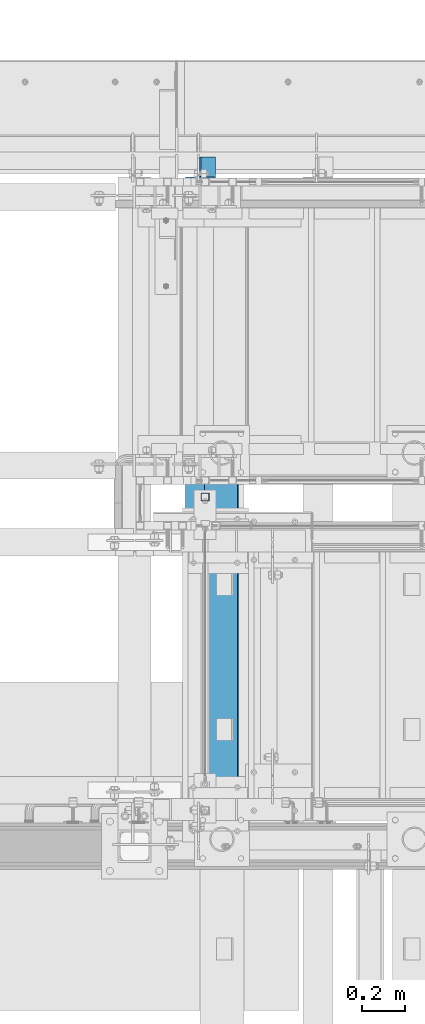
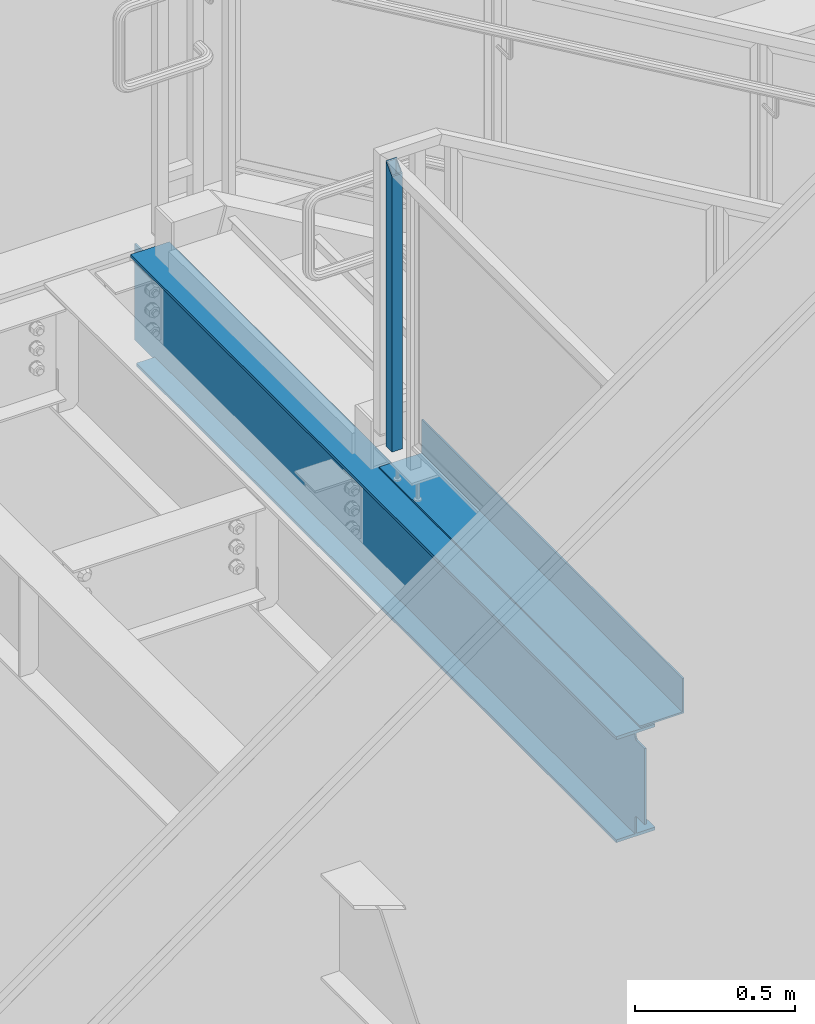
# One storey, part 780 of 1179: 2 beams, 1 member, 2 elements without a shape of their own.
"""IFC2X3 building model written with IfcOpenShell, lengths in millimetres."""

from ifc_helpers import new_model, si_unit, frame, origin_with_axes, place, context, subcontext, project, spatial, faceted_brep, material, type_object, element, aggregate, save


model = new_model("IFC2X3")

# Units and contexts
model_context = context("Model", 3, precision=1e-05, world=origin_with_axes())
body_context = subcontext(model_context, "Body", "Model", "MODEL_VIEW")
ifc_project = project(units=[si_unit("LENGTHUNIT", "METRE", prefix="MILLI"), si_unit("AREAUNIT", "SQUARE_METRE"), si_unit("VOLUMEUNIT", "CUBIC_METRE"), si_unit("MASSUNIT", "GRAM", prefix="KILO"), si_unit("TIMEUNIT", "SECOND"), si_unit("PLANEANGLEUNIT", "RADIAN"), si_unit("SOLIDANGLEUNIT", "STERADIAN"), si_unit("THERMODYNAMICTEMPERATUREUNIT", "DEGREE_CELSIUS"), si_unit("LUMINOUSINTENSITYUNIT", "LUMEN")], contexts=[model_context])

# Site, building, storey
site_placement = place(None, origin_with_axes())
site = spatial("IfcSite", under=ifc_project, at=site_placement, CompositionType="ELEMENT")
building_placement = place(site_placement, origin_with_axes())
building = spatial("IfcBuilding", under=site, at=building_placement, Name="Undefined", CompositionType="ELEMENT")
storey_placement = place(building_placement, origin_with_axes())
storey = spatial("IfcBuildingStorey", under=building, at=storey_placement, Name="Undefined", CompositionType="ELEMENT", Elevation=0.0)

# Assembly, member
assembly_1_placement = place(storey_placement, origin_with_axes())
assembly_1 = element("IfcElementAssembly", 1, at=assembly_1_placement, inside=storey, Name="GUARDRAIL", AssemblyPlace="NOTDEFINED", PredefinedType="RIGID_FRAME")
ifc_material_1 = material()
member_type = type_object("IfcMemberType", Name="HSS1-1/2X1-1/2X1/8", PredefinedType="NOTDEFINED")
member_placement = place(assembly_1_placement, frame((19605.6249999269, 39604.950001563, 8147.05), z_axis=(-1.0, 0.0, 0.0), x_axis=(0.0, 0.0, 1.0)))
member = element("IfcMember", 2, at=member_placement, type_object=member_type, material=ifc_material_1, Name="POST", ObjectType="HSS1-1/2X1-1/2X1/8", context=body_context, shape_type="Brep", body=[
    faceted_brep([(0.0, 15.8749992830017, -15.8749992829999), (0.0, -15.8749992830017, -15.8749992829999), (1050.92500131295, -15.874999282998, -15.8749992830017), (1082.67499987894, 15.874999282998, -15.8749992830017), (0.0, -15.8749992830017, 15.8749992829999), (1050.92500131295, -15.874999282998, 15.8749992830017), (0.0, 15.8749992830017, 15.8749992829999), (1082.67499987894, 15.874999282998, 15.8749992830017), (0.0, 19.0499992350015, -19.0499992349996), (0.0, 19.0499992350015, 19.0499992349996), (1085.84999983094, 19.0499992350015, 19.0499992350015), (1085.84999983094, 19.0499992350015, -19.0499992350015), (0.0, -19.0499992350015, 19.0499992349996), (1047.74999838855, -19.0499992350015, 19.0499992350015), (0.0, -19.0499992350015, -19.0499992349996), (1047.74999838855, -19.0499992350015, -19.0499992350015)], [[[0, 1, 2, 3]], [[1, 4, 5, 2]], [[4, 6, 7, 5]], [[6, 0, 3, 7]], [[8, 9, 10, 11]], [[9, 12, 13, 10]], [[12, 14, 15, 13]], [[14, 8, 11, 15]], [[13, 15, 11, 10], [5, 7, 3, 2]], [[14, 12, 9, 8], [6, 4, 1, 0]]]),
])
aggregate(assembly_1, [member])

# Assembly, beams
assembly_2_placement = place(storey_placement, origin_with_axes())
assembly_2 = element("IfcElementAssembly", 3, at=assembly_2_placement, inside=storey, Name="BEAM", AssemblyPlace="NOTDEFINED", PredefinedType="RIGID_FRAME")
ifc_material_2 = material(Name="STEEL/A36")
beam_type_1 = type_object("IfcBeamType", PredefinedType="NOTDEFINED")
beam_1_placement = place(assembly_2_placement, frame((19602.45, 38881.05, 8016.875), z_axis=(0.0, -1.0, 0.0), x_axis=(1.0, 0.0, 0.0)))
beam_1 = element("IfcBeam", 4, at=beam_1_placement, type_object=beam_type_1, material=ifc_material_2, Name="BENT PLATE", context=body_context, shape_type="Brep", body=[
    faceted_brep([(0.0, -3.17500000000018, -812.800000000003), (0.0, -3.17500000000018, 812.800000000003), (0.0, 3.17500000000018, 812.800000000003), (0.0, 3.17500000000018, -812.800000000003), (152.400000000005, 3.17500000000291, 812.800000000003), (152.400000000005, 3.17500000000291, -812.800000000003), (158.750000000004, -3.17499999999745, -812.800000000003), (158.750000000004, -3.17499999999745, 812.800000000003), (152.400000000005, 130.175000000003, 812.800000000003), (152.400000000005, 130.175000000003, -812.800000000003), (158.750000000004, 130.175000000003, 812.800000000003), (158.750000000004, 130.175000000003, -812.800000000003)], [[[0, 1, 2, 3]], [[3, 2, 4, 5]], [[1, 0, 6, 7]], [[5, 4, 8, 9]], [[4, 2, 1, 7, 10, 8]], [[7, 6, 11, 10]], [[6, 0, 3, 5, 9, 11]], [[10, 11, 9, 8]]]),
])
ifc_material_3 = material(Name="STEEL/A992")
beam_type_2 = type_object("IfcBeamType", Name="W16X31", PredefinedType="NOTDEFINED")
beam_2_placement = place(assembly_2_placement, frame((19583.4, 37985.7, 7812.0875), z_axis=(0.0, 0.0, 1.0), x_axis=(0.0, 1.0, 0.0)))
beam_2 = element("IfcBeam", 5, at=beam_2_placement, type_object=beam_type_2, material=ifc_material_3, Name="BEAM", ObjectType="W16X31", context=body_context, shape_type="Brep", body=[
    faceted_brep([(15.875, -3.17499999999927, -119.0625), (15.875, 3.17499999999927, -119.0625), (63.5000001907247, 3.17499999999927, -119.0625), (63.5000001907247, -3.17499999999927, -119.0625), (68.3600797087711, 3.17499999999927, -120.029229922588), (68.3600797087711, -3.17499999999927, -120.029229922588), (72.4802561769247, 3.17499999999927, -122.782243823066), (72.4802561769247, -3.17499999999927, -122.782243823066), (75.2332700773986, 3.17499999999927, -126.90242029122), (75.2332700773986, -3.17499999999927, -126.90242029122), (76.1999999999898, -3.17499999999927, -131.762499809265), (76.1999999999898, 3.17499999999927, -131.762499809265), (76.1999999999898, 3.17499999999927, -190.5), (76.1999999999898, 69.8499999999985, -190.5), (76.1999999999898, 69.8499999999985, -201.6125), (76.1999999999898, -69.8499999999985, -201.6125), (76.1999999999898, -69.8499999999985, -190.5), (76.1999999999898, -3.17499999999927, -190.5), (3102.76875, 69.8499999999985, 190.5), (3102.76875, 3.17499999999927, 190.5), (76.1999999999898, 3.17499999999927, 190.5), (76.1999999999898, 69.8499999999985, 190.5), (63.5000001907247, -3.17499999999927, 169.8625), (63.5000001907247, 3.17499999999927, 169.8625), (15.875, 3.17499999999927, 169.8625), (15.875, -3.17499999999927, 169.8625), (68.3600797087711, -3.17499999999927, 170.829229922588), (68.3600797087711, 3.17499999999927, 170.829229922588), (72.4802561769247, -3.17499999999927, 173.582243823066), (72.4802561769247, 3.17499999999927, 173.582243823066), (75.2332700773986, -3.17499999999927, 177.70242029122), (75.2332700773986, 3.17499999999927, 177.70242029122), (76.1999999999898, -3.17499999999927, 182.562499809265), (76.1999999999898, 3.17499999999927, 182.562499809265), (3102.76875, -69.8499999999985, 201.6125), (3102.76875, 69.8499999999985, 201.6125), (76.1999999999898, 69.8499999999985, 201.6125), (76.1999999999898, -69.8499999999985, 201.6125), (3102.76875, -69.8499999999985, 190.5), (76.1999999999898, -69.8499999999985, 190.5), (3102.76875, -3.17499999999927, 190.5), (76.1999999999898, -3.17499999999927, 190.5), (3102.76875, -3.17499999999927, 176.212499809266), (3102.76875, 3.17499999999927, 176.212499809266), (3102.76875, 3.17499999999927, 181.715), (3103.73547992259, -3.17499999999927, 171.35242029122), (3103.73547992259, 3.17499999999927, 171.35242029122), (3106.48849382307, -3.17499999999927, 167.232243823067), (3106.48849382307, 3.17499999999927, 167.232243823067), (3110.60867029122, -3.17499999999927, 164.479229922588), (3110.60867029122, 3.17499999999927, 164.479229922588), (3115.46874980927, -3.17499999999927, 163.512500000001), (3115.46874980927, 3.17499999999927, 163.512500000001), (3194.84375, -3.17499999999927, 163.512500000001), (3194.84375, 3.17499999999927, 163.512500000001), (3067.84375, 3.17499999999927, -190.5), (3067.84375, 3.17549991607666, -201.6125), (3067.84375, 69.8499999999985, -201.6125), (3067.84375, 69.8499999999985, -190.5), (3194.84375, 3.17499999999927, -190.5), (3194.84375, 3.17549991607666, -201.6125), (3194.84375, -3.17499999999927, -190.5), (3194.84375, -69.8499999999985, -190.5), (3194.84375, -69.8499999999985, -201.6125)], [[[0, 1, 2, 3]], [[3, 2, 4, 5]], [[5, 4, 6, 7]], [[7, 6, 8, 9]], [[10, 11, 12, 13, 14, 15, 16, 17]], [[9, 8, 11, 10]], [[18, 19, 20, 21]], [[22, 23, 24, 25]], [[26, 27, 23, 22]], [[28, 29, 27, 26]], [[30, 31, 29, 28]], [[32, 33, 31, 30]], [[34, 35, 36, 37]], [[38, 34, 37, 39]], [[40, 38, 39, 41]], [[37, 36, 21, 20, 33, 32, 41, 39]], [[35, 18, 21, 36]], [[34, 38, 40, 42, 43, 44, 19, 18, 35]], [[45, 46, 43, 42]], [[47, 48, 46, 45]], [[49, 50, 48, 47]], [[51, 52, 50, 49]], [[53, 54, 52, 51]], [[55, 56, 57, 58]], [[59, 60, 56, 55]], [[54, 53, 61, 62, 63, 60, 59]], [[62, 61, 17, 16]], [[63, 62, 16, 15]], [[57, 56, 60, 63, 15, 14]], [[58, 57, 14, 13]], [[55, 58, 13, 12]], [[6, 4, 2, 1, 24, 23, 27, 29, 31, 33, 20, 19, 44, 43, 46, 48, 50, 52, 54, 59, 55, 12, 11, 8]], [[25, 24, 1, 0]], [[61, 53, 51, 49, 47, 45, 42, 40, 41, 32, 30, 28, 26, 22, 25, 0, 3, 5, 7, 9, 10, 17]]]),
])
aggregate(assembly_2, [beam_1, beam_2])

save(model, "model.ifc")
